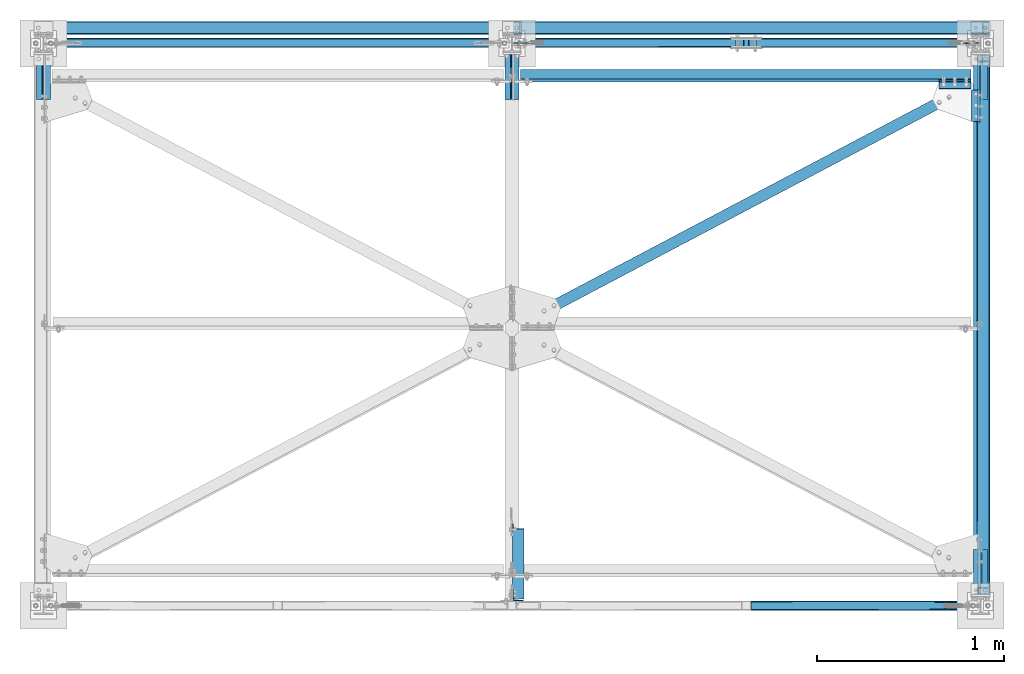
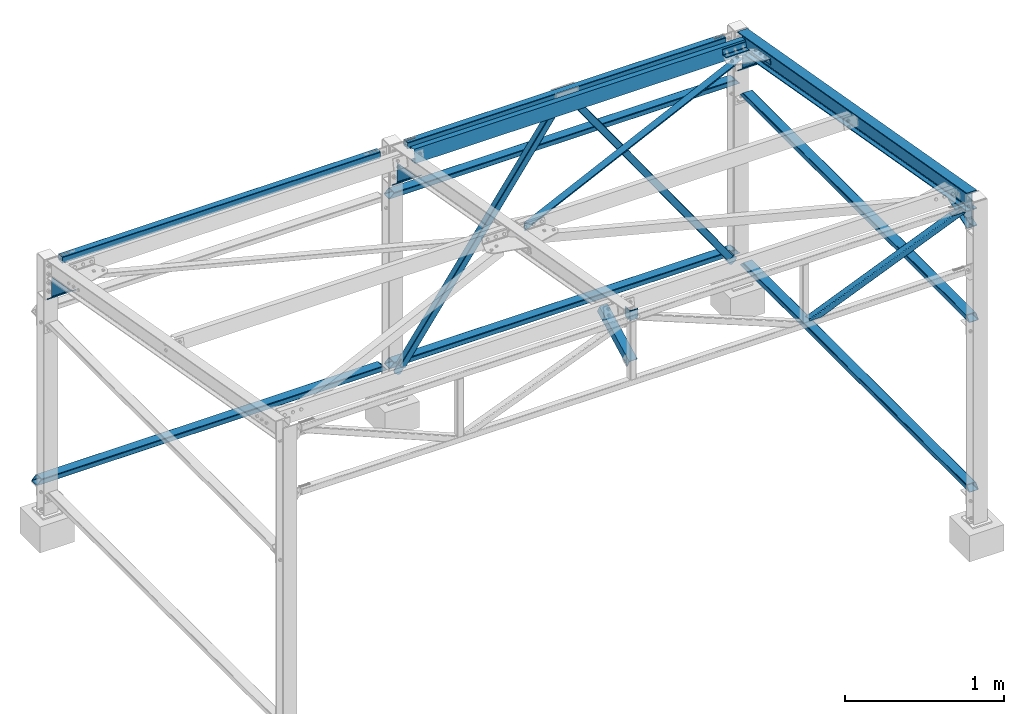
# One storey, part 6 of 28: 14 beams, 9 members, 19 elements without a shape of their own.
"""IFC2X3 building model written with IfcOpenShell, lengths in millimetres."""

from ifc_helpers import new_model, si_unit, frame, origin_with_axes, origin_2d_with_axis, place, context, subcontext, project, spatial, rectangle, hollow_rectangle, i_section, l_section, c_section, extrude, boolean, clip, halfspace, material, type_object, element, aggregate, save


model = new_model("IFC2X3")

# Units and contexts
model_context = context("Model", 3, precision=1e-05, world=origin_with_axes())
body_context = subcontext(model_context, "Body", "Model", "MODEL_VIEW")
ifc_project = project(units=[si_unit("LENGTHUNIT", "METRE", prefix="MILLI"), si_unit("AREAUNIT", "SQUARE_METRE"), si_unit("VOLUMEUNIT", "CUBIC_METRE"), si_unit("MASSUNIT", "GRAM", prefix="KILO"), si_unit("TIMEUNIT", "SECOND"), si_unit("PLANEANGLEUNIT", "RADIAN"), si_unit("SOLIDANGLEUNIT", "STERADIAN"), si_unit("THERMODYNAMICTEMPERATUREUNIT", "DEGREE_CELSIUS"), si_unit("LUMINOUSINTENSITYUNIT", "LUMEN")], contexts=[model_context])

# Site, building, storey
site_placement = place(None, origin_with_axes())
site = spatial("IfcSite", under=ifc_project, at=site_placement, CompositionType="ELEMENT")
building_placement = place(site_placement, origin_with_axes())
building = spatial("IfcBuilding", under=site, at=building_placement, Name="Undefined", CompositionType="ELEMENT")
storey_placement = place(building_placement, origin_with_axes())
storey = spatial("IfcBuildingStorey", under=building, at=storey_placement, Name="Undefined", CompositionType="ELEMENT", Elevation=0.0)

# Assembly, member
assembly_1_placement = place(storey_placement, origin_with_axes())
assembly_1 = element("IfcElementAssembly", 1, at=assembly_1_placement, inside=storey, AssemblyPlace="NOTDEFINED", PredefinedType="NOTDEFINED")
ifc_material = material(Name="STEEL/S235JR")
member_type_1 = type_object("IfcMemberType", PredefinedType="NOTDEFINED")
member_1_placement = place(assembly_1_placement, frame((2584.59141781724, 3000.0, 452.793341408176), z_axis=(-0.816342906816188, 0.0, 0.577567535869959), x_axis=(-0.577567535869955, 0.0, -0.816342906816191)))
member_1 = element("IfcMember", 2, at=member_1_placement, type_object=member_type_1, material=ifc_material, context=body_context, shape_type="Clipping", body=[
    clip(clip(extrude(rectangle(XDim=6.0, YDim=60.0, at=origin_2d_with_axis()), frame((101.822640541409, -4.54747350886464e-13, 5.65229199786016e-15), z_axis=(-1.0, 0.0, 0.0), x_axis=(0.0, -1.0, 0.0)), (0.0, 0.0, 1.0), 101.82), halfspace(frame((146.82264054141, 2.99999999999955, -30.0000000000002), z_axis=(0.707106781249556, 0.0, 0.707106781123539), x_axis=(0.0, -1.0, 0.0)), False)), halfspace(frame((91.8226405414016, 2.99999999999955, -30.0000000000002), z_axis=(0.707106781123535, 0.0, -0.70710678124956), x_axis=(0.0, -1.0, 0.0)), False)),
])

assembly_2_placement = place(storey_placement, origin_with_axes())
assembly_2 = element("IfcElementAssembly", 3, at=assembly_2_placement, inside=storey, AssemblyPlace="NOTDEFINED", PredefinedType="NOTDEFINED")
member_2_placement = place(assembly_2_placement, frame((4915.40858218276, 3000.0, 452.793341408176), z_axis=(0.816342906816193, 0.0, 0.577567535869952), x_axis=(0.577567535869956, 0.0, -0.81634290681619)))
member_2 = element("IfcMember", 4, at=member_2_placement, type_object=member_type_1, material=ifc_material, context=body_context, shape_type="Clipping", body=[
    clip(clip(extrude(rectangle(XDim=6.0, YDim=60.0, at=origin_2d_with_axis()), frame((101.822640541409, -4.54747350886464e-13, 5.65229199786016e-15), z_axis=(-1.0, 0.0, 0.0), x_axis=(0.0, -1.0, 0.0)), (0.0, 0.0, 1.0), 101.82), halfspace(frame((146.82264054141, -3.00000000000045, -30.0000000000009), z_axis=(0.707106781249556, 0.0, 0.707106781123539), x_axis=(-0.707106781123536, 0.0, 0.707106781249559)), False)), halfspace(frame((91.8226405414016, -3.00000000000045, -30.0), z_axis=(0.707106781123535, 0.0, -0.70710678124956), x_axis=(0.707106781249556, 0.0, 0.707106781123539)), False)),
])

# Member
member_type_2 = type_object("IfcMemberType", PredefinedType="NOTDEFINED")
member_3_placement = place(assembly_1_placement, frame((2528.38079886693, 3003.11000000016, 373.344381385333), z_axis=(0.0, -1.0, 0.0), x_axis=(0.577567535869954, 0.0, 0.816342906816191)))
solid_1 = boolean("DIFFERENCE", extrude(rectangle(XDim=6.0, YDim=60.0, at=origin_2d_with_axis()), frame((-4.49961689598291, -9.17407910569932e-12, 3.11000000015792), z_axis=(1.0, 0.0, 0.0), x_axis=(0.0, 0.0, -1.0)), (0.0, 0.0, 1.0), 101.82), halfspace(frame((-49.4996168959854, -30.0000000000095, 6.11000000015792), z_axis=(-0.707106781249559, 0.707106781123536, 0.0), x_axis=(0.0, 0.0, -1.0)), False))
solid_2 = boolean("DIFFERENCE", extrude(rectangle(XDim=6.0, YDim=60.0, at=origin_2d_with_axis()), frame((-4.49961689598291, -9.17407910569932e-12, 3.11000000015792), z_axis=(1.0, 0.0, 0.0), x_axis=(0.0, 0.0, -1.0)), (0.0, 0.0, 1.0), 101.82), halfspace(frame((-49.4996168959854, -30.0000000000095, 6.11000000015792), z_axis=(-0.707106781249559, 0.707106781123536, 0.0), x_axis=(0.0, 0.0, -1.0)), False))
member_3 = element("IfcMember", 5, at=member_3_placement, type_object=member_type_2, material=ifc_material, context=body_context, shape_type="CSG", body=[
    boolean("DIFFERENCE", boolean("DIFFERENCE", boolean("DIFFERENCE", boolean("DIFFERENCE", extrude(hollow_rectangle(XDim=50.0, YDim=50.0, WallThickness=3.0, InnerFilletRadius=3.0, OuterFilletRadius=6.0, at=origin_2d_with_axis()), frame((2159.92057273327, 3.59699032681505e-13, 0.0), z_axis=(-1.0, 0.0, 0.0), x_axis=(0.0, -1.0, 0.0)), (0.0, 0.0, 1.0), 2159.92), solid_1), solid_2), halfspace(frame((2056.2476454801, 23.738158636309, -24.9999999997331), z_axis=(0.999768192719064, 0.0215304627738772, 0.0), x_axis=(0.0215304627738772, -0.999768192719064, 0.0)), False)), halfspace(frame((57.323023645426, -24.9999999999995, -25.0), z_axis=(-1.0, 0.0, 0.0), x_axis=(0.0, 1.0, 0.0)), False)),
])

aggregate(assembly_1, [member_1, member_3])

member_4_placement = place(assembly_2_placement, frame((4971.61920113307, 3003.11000000016, 373.344381385333), z_axis=(0.0, -1.0, 0.0), x_axis=(-0.577567535869954, 0.0, 0.816342906816191)))
solid_3 = boolean("DIFFERENCE", extrude(rectangle(XDim=6.0, YDim=60.0, at=origin_2d_with_axis()), frame((-4.49961689598291, -9.17407910569932e-12, 3.11000000015792), z_axis=(1.0, 0.0, 0.0), x_axis=(0.0, 0.0, 1.0)), (0.0, 0.0, 1.0), 101.82), halfspace(frame((-49.4996168959851, 30.00000000001, 6.11000000015792), z_axis=(-0.707106781186548, -0.707106781186548, 0.0), x_axis=(0.707106781123531, -0.707106781249564, 0.0)), False))
member_4 = element("IfcMember", 6, at=member_4_placement, type_object=member_type_2, material=ifc_material, context=body_context, shape_type="CSG", body=[
    boolean("DIFFERENCE", boolean("DIFFERENCE", boolean("DIFFERENCE", extrude(hollow_rectangle(XDim=50.0, YDim=50.0, WallThickness=3.0, InnerFilletRadius=3.0, OuterFilletRadius=6.0, at=origin_2d_with_axis()), frame((2159.92057273327, 3.59699032681505e-13, 0.0), z_axis=(-1.0, 0.0, 0.0), x_axis=(0.0, -1.0, 0.0)), (0.0, 0.0, 1.0), 2159.92), solid_3), halfspace(frame((57.323023645426, 24.9999999999991, -25.0), z_axis=(-1.0, 0.0, 0.0), x_axis=(0.0, 0.0, 1.0)), False)), halfspace(frame((2056.2476454801, -23.738158636309, -24.9999999997331), z_axis=(0.999768192719064, -0.0215304627738776, 0.0), x_axis=(0.0, 0.0, 1.0)), False)),
])

aggregate(assembly_2, [member_2, member_4])

# Assembly, beam
assembly_3_placement = place(storey_placement, origin_with_axes())
assembly_3 = element("IfcElementAssembly", 7, at=assembly_3_placement, inside=storey, Name="FA", AssemblyPlace="NOTDEFINED", PredefinedType="NOTDEFINED")
beam_type_1 = type_object("IfcBeamType", PredefinedType="NOTDEFINED")
beam_1_placement = place(assembly_3_placement, frame((2532.51, 55.0, 2660.99989966715), z_axis=(0.0, 1.0, 0.0), x_axis=(0.0, 0.0, -1.0)))
beam_1 = element("IfcBeam", 8, at=beam_1_placement, type_object=beam_type_1, material=ifc_material, Name="FA", context=body_context, shape_type="SweptSolid", body=[
    extrude(l_section(Depth=60.0, Width=60.0, Thickness=6.0, FilletRadius=9.0, at=origin_2d_with_axis()), frame((75.0, 0.0, 0.0), z_axis=(-1.0, 0.0, 0.0), x_axis=(0.0, -1.0, 0.0)), (0.0, 0.0, 1.0), 75.0),
])
aggregate(assembly_3, [beam_1])

assembly_4_placement = place(storey_placement, origin_with_axes())
assembly_4 = element("IfcElementAssembly", 9, at=assembly_4_placement, inside=storey, AssemblyPlace="NOTDEFINED", PredefinedType="NOTDEFINED")
beam_type_2 = type_object("IfcBeamType", PredefinedType="NOTDEFINED")
beam_2_placement = place(assembly_4_placement, frame((4947.65000011394, 2782.58003669103, 2163.62774213601), z_axis=(0.0, -0.984742283021841, 0.17401906800386), x_axis=(-1.0, 0.0, 0.0)))
beam_2 = element("IfcBeam", 10, at=beam_2_placement, type_object=beam_type_2, material=ifc_material, context=body_context, shape_type="SweptSolid", body=[
    extrude(l_section(Depth=45.0, Width=45.0, Thickness=4.0, FilletRadius=7.0, EdgeRadius=3.5, at=origin_2d_with_axis()), frame((169.999999999638, 0.0, 0.0), z_axis=(-1.0, 0.0, 0.0), x_axis=(0.0, -1.0, 0.0)), (0.0, 0.0, 1.0), 170.0),
])
aggregate(assembly_4, [beam_2])

assembly_5_placement = place(storey_placement, origin_with_axes())
assembly_5 = element("IfcElementAssembly", 11, at=assembly_5_placement, inside=storey, AssemblyPlace="NOTDEFINED", PredefinedType="NOTDEFINED")
beam_3_placement = place(assembly_5_placement, frame((4975.15000012328, 2746.45063233392, 2117.20666749448), z_axis=(-1.0, 0.0, 0.0), x_axis=(0.0, -0.984742283021841, 0.17401906800386)))
beam_3 = element("IfcBeam", 12, at=beam_3_placement, type_object=beam_type_2, material=ifc_material, context=body_context, shape_type="SweptSolid", body=[
    extrude(l_section(Depth=45.0, Width=45.0, Thickness=4.0, FilletRadius=7.0, EdgeRadius=3.5, at=origin_2d_with_axis()), frame((169.999999999638, 0.0, 0.0), z_axis=(-1.0, 0.0, 0.0), x_axis=(0.0, -1.0, 0.0)), (0.0, 0.0, 1.0), 170.0),
])
aggregate(assembly_5, [beam_3])

# Assembly, member
assembly_6_placement = place(storey_placement, origin_with_axes())
assembly_6 = element("IfcElementAssembly", 13, at=assembly_6_placement, inside=storey, AssemblyPlace="NOTDEFINED", PredefinedType="NOTDEFINED")
member_type_3 = type_object("IfcMemberType", Name="IPE140", PredefinedType="NOTDEFINED")
member_5_placement = place(assembly_6_placement, frame((2499.99999999997, 2984.1132847924, 1922.77267917178), z_axis=(0.0, 0.630189782914748, 0.776441135894964), x_axis=(0.0, -0.776441135894964, 0.630189782914748)))
member_5 = element("IfcMember", 14, at=member_5_placement, type_object=member_type_3, material=ifc_material, context=body_context, shape_type="Clipping", body=[
    clip(clip(clip(extrude(i_section(OverallWidth=73.0, OverallDepth=140.0, WebThickness=4.699999809, FlangeThickness=6.900000095, FilletRadius=7.0, at=origin_2d_with_axis()), frame((538.073020824243, 0.0, -8.96071584973028e-14), z_axis=(-1.0, 0.0, 0.0), x_axis=(0.0, -1.0, 0.0)), (0.0, 0.0, 1.0), 653.41), halfspace(frame((75.0040214740868, 36.5, 70.0), z_axis=(0.485458962736208, 0.0, 0.874259455481658), x_axis=(0.874259455481658, 0.0, -0.485458962736208)), False)), halfspace(frame((309.102633600927, 1.54614099301398e-11, -70.0000000728337), z_axis=(0.776441135894964, 0.0, -0.630189782914748), x_axis=(0.0, -1.0, 0.0)), False)), halfspace(frame((821.412970664735, 1.54614099301398e-11, 942.042462898728), z_axis=(-0.776441135894964, 0.0, 0.630189782914748), x_axis=(0.0, -1.0, 0.0)), False)),
])
aggregate(assembly_6, [member_5])

assembly_7_placement = place(storey_placement, origin_with_axes())
assembly_7 = element("IfcElementAssembly", 15, at=assembly_7_placement, inside=storey, AssemblyPlace="NOTDEFINED", PredefinedType="NOTDEFINED")
member_6_placement = place(assembly_7_placement, frame((5000.00000000163, 2984.11328479234, 1922.77267917227), z_axis=(0.0, 0.630189782914748, 0.776441135894964), x_axis=(0.0, -0.776441135894964, 0.630189782914748)))
member_6 = element("IfcMember", 16, at=member_6_placement, type_object=member_type_3, material=ifc_material, context=body_context, shape_type="Clipping", body=[
    clip(clip(clip(extrude(i_section(OverallWidth=73.0, OverallDepth=140.0, WebThickness=4.699999809, FlangeThickness=6.900000095, FilletRadius=7.0, at=origin_2d_with_axis()), frame((538.073020824243, 0.0, -8.96071584973028e-14), z_axis=(-1.0, 0.0, 0.0), x_axis=(0.0, -1.0, 0.0)), (0.0, 0.0, 1.0), 653.41), halfspace(frame((75.0040214740868, 36.5, 70.0), z_axis=(0.485458962736208, 0.0, 0.874259455481658), x_axis=(0.874259455481658, 0.0, -0.485458962736208)), False)), halfspace(frame((309.102633600927, 1.54614099301398e-11, -70.0000000728337), z_axis=(0.776441135894964, 0.0, -0.630189782914748), x_axis=(0.0, -1.0, 0.0)), False)), halfspace(frame((821.412970664735, 1.54614099301398e-11, 942.042462898728), z_axis=(-0.776441135894964, 0.0, 0.630189782914748), x_axis=(0.0, -1.0, 0.0)), False)),
])

assembly_8_placement = place(storey_placement, origin_with_axes())
assembly_8 = element("IfcElementAssembly", 17, at=assembly_8_placement, inside=storey, AssemblyPlace="NOTDEFINED", PredefinedType="NOTDEFINED")
member_7_placement = place(assembly_8_placement, frame((-4.16338693337359e-10, 2984.11328479246, 1922.77267917177), z_axis=(0.0, 0.630189782914748, 0.776441135894964), x_axis=(0.0, -0.776441135894964, 0.630189782914748)))
member_7 = element("IfcMember", 18, at=member_7_placement, type_object=member_type_3, material=ifc_material, context=body_context, shape_type="Clipping", body=[
    clip(clip(clip(extrude(i_section(OverallWidth=73.0, OverallDepth=140.0, WebThickness=4.699999809, FlangeThickness=6.900000095, FilletRadius=7.0, at=origin_2d_with_axis()), frame((538.073020824243, 0.0, -8.96071584973028e-14), z_axis=(-1.0, 0.0, 0.0), x_axis=(0.0, -1.0, 0.0)), (0.0, 0.0, 1.0), 653.41), halfspace(frame((75.0040214740868, 36.5, 70.0), z_axis=(0.485458962736208, 0.0, 0.874259455481658), x_axis=(0.874259455481658, 0.0, -0.485458962736208)), False)), halfspace(frame((309.102633600927, 1.54614099301398e-11, -70.0000000728337), z_axis=(0.776441135894964, 0.0, -0.630189782914748), x_axis=(0.0, -1.0, 0.0)), False)), halfspace(frame((821.412970664735, 1.54614099301398e-11, 942.042462898728), z_axis=(-0.776441135894964, 0.0, 0.630189782914748), x_axis=(0.0, -1.0, 0.0)), False)),
])
aggregate(assembly_8, [member_7])

# Assembly, beam
assembly_9_placement = place(storey_placement, origin_with_axes())
assembly_9 = element("IfcElementAssembly", 19, at=assembly_9_placement, inside=storey, AssemblyPlace="NOTDEFINED", PredefinedType="NOTDEFINED")
beam_type_3 = type_object("IfcBeamType", PredefinedType="NOTDEFINED")
beam_4_placement = place(assembly_9_placement, frame((5015.00000000054, 3000.00000000009, 1699.9998958987), z_axis=(1.0, 0.0, 0.0), x_axis=(0.0, -1.0, 0.0)))
beam_4 = element("IfcBeam", 20, at=beam_4_placement, type_object=beam_type_3, material=ifc_material, context=body_context, shape_type="Clipping", body=[
    clip(clip(clip(clip(clip(clip(extrude(hollow_rectangle(XDim=40.0, YDim=70.0, WallThickness=3.0, InnerFilletRadius=3.0, OuterFilletRadius=6.0, at=origin_2d_with_axis()), frame((3000.0, 0.0, 0.0), z_axis=(-1.0, 0.0, 0.0), x_axis=(0.0, -1.0, 0.0)), (0.0, 0.0, 1.0), 3000.0), halfspace(frame((63.0031151709718, -20.0000000001187, -35.0000000000191), z_axis=(-1.0, 0.0, 0.0), x_axis=(0.0, 1.0, 0.0)), False)), halfspace(frame((98.0031151678127, -20.0000000001191, -35.00000000002), z_axis=(-0.707079247150489, -0.7071343141505, 0.0), x_axis=(-0.7071343141505, 0.707079247150489, 0.0)), False)), halfspace(frame((2936.99688482905, -20.0000000001187, -35.0000000000191), z_axis=(1.0, 0.0, 0.0), x_axis=(0.0, 0.0, 1.0)), False)), halfspace(frame((2901.99688483221, -20.0000000001191, -35.0000000000191), z_axis=(0.707079247150487, -0.707134314150502, 0.0), x_axis=(0.0, 0.0, 1.0)), False)), halfspace(frame((47.9999999999882, 20.0000000000045, -40.0000000000064), z_axis=(-1.0, 0.0, 0.0), x_axis=(0.0, 0.0, 1.0)), False)), halfspace(frame((2942.00000000001, -20.0000000000045, -40.0000000000064), z_axis=(1.0, 0.0, 0.0), x_axis=(0.0, 0.0, 1.0)), False)),
])
aggregate(assembly_9, [beam_4])

assembly_10_placement = place(storey_placement, origin_with_axes())
assembly_10 = element("IfcElementAssembly", 21, at=assembly_10_placement, inside=storey, AssemblyPlace="NOTDEFINED", PredefinedType="NOTDEFINED")
beam_5_placement = place(assembly_10_placement, frame((5015.00000000052, 3000.0000000004, 399.999895898523), z_axis=(1.0, 0.0, 0.0), x_axis=(0.0, -1.0, 0.0)))
beam_5 = element("IfcBeam", 22, at=beam_5_placement, type_object=beam_type_3, material=ifc_material, context=body_context, shape_type="Clipping", body=[
    clip(clip(clip(clip(clip(clip(extrude(hollow_rectangle(XDim=40.0, YDim=70.0, WallThickness=3.0, InnerFilletRadius=3.0, OuterFilletRadius=6.0, at=origin_2d_with_axis()), frame((3000.00109932641, 0.0, 0.0), z_axis=(-1.0, 0.0, 0.0), x_axis=(0.0, -1.0, 0.0)), (0.0, 0.0, 1.0), 3000.0), halfspace(frame((63.0031151709718, -20.0000000001187, -35.0000000000191), z_axis=(-1.0, 0.0, 0.0), x_axis=(0.0, 1.0, 0.0)), False)), halfspace(frame((98.0031151678127, -20.0000000001191, -35.00000000002), z_axis=(-0.707079247150489, -0.7071343141505, 0.0), x_axis=(-0.7071343141505, 0.707079247150489, 0.0)), False)), halfspace(frame((2936.99688482905, -20.0000000001187, -35.0000000000191), z_axis=(1.0, 0.0, 0.0), x_axis=(0.0, 0.0, 1.0)), False)), halfspace(frame((2901.99688483221, -20.0000000001191, -35.0000000000191), z_axis=(0.707079247150487, -0.707134314150502, 0.0), x_axis=(0.0, 0.0, 1.0)), False)), halfspace(frame((47.9999999999882, 20.0000000000045, -40.0000000000064), z_axis=(-1.0, 0.0, 0.0), x_axis=(0.0, 0.0, 1.0)), False)), halfspace(frame((2942.00000000001, -20.0000000000045, -40.0000000000064), z_axis=(1.0, 0.0, 0.0), x_axis=(0.0, 0.0, 1.0)), False)),
])
aggregate(assembly_10, [beam_5])

assembly_11_placement = place(storey_placement, origin_with_axes())
assembly_11 = element("IfcElementAssembly", 23, at=assembly_11_placement, inside=storey, AssemblyPlace="NOTDEFINED", PredefinedType="NOTDEFINED")
beam_6_placement = place(assembly_11_placement, frame((2499.99999999999, 3083.00000000085, 399.999895901682), z_axis=(0.0, -1.0, 0.0), x_axis=(-1.0, 0.0, 0.0)))
beam_6 = element("IfcBeam", 24, at=beam_6_placement, type_object=beam_type_3, material=ifc_material, context=body_context, shape_type="Clipping", body=[
    clip(clip(clip(clip(extrude(hollow_rectangle(XDim=40.0, YDim=70.0, WallThickness=3.0, InnerFilletRadius=3.0, OuterFilletRadius=6.0, at=origin_2d_with_axis()), frame((2550.00000000037, 0.0, 0.0), z_axis=(-1.0, 0.0, 0.0), x_axis=(0.0, -1.0, 0.0)), (0.0, 0.0, 1.0), 2550.0), halfspace(frame((2545.00000000037, -20.0000000000045, -35.0000000000159), z_axis=(1.0, 0.0, 0.0), x_axis=(0.0, 0.0, 1.0)), False)), halfspace(frame((7.5, 20.0000000000045, -35.0000000000118), z_axis=(-1.0, 0.0, 0.0), x_axis=(0.0, 0.0, 1.0)), False)), halfspace(frame((2.50000000003047, 20.0000000004552, -35.0000000000719), z_axis=(-0.707106781186548, -0.707106781186548, 0.0), x_axis=(0.0, 0.0, 1.0)), False)), halfspace(frame((2521.71572875313, -8.28427124701284, -35.0000000001091), z_axis=(0.707106781123531, -0.707106781249564, 0.0), x_axis=(0.0, 0.0, 1.0)), False)),
])
aggregate(assembly_11, [beam_6])

assembly_12_placement = place(storey_placement, origin_with_axes())
assembly_12 = element("IfcElementAssembly", 25, at=assembly_12_placement, inside=storey, AssemblyPlace="NOTDEFINED", PredefinedType="NOTDEFINED")
beam_7_placement = place(assembly_12_placement, frame((5050.00000000036, 3083.00000000009, 1699.99989590197), z_axis=(0.0, -1.0, 0.0), x_axis=(-1.0, 0.0, 0.0)))
beam_7 = element("IfcBeam", 26, at=beam_7_placement, type_object=beam_type_3, material=ifc_material, context=body_context, shape_type="Clipping", body=[
    clip(clip(clip(clip(extrude(hollow_rectangle(XDim=40.0, YDim=70.0, WallThickness=3.0, InnerFilletRadius=3.0, OuterFilletRadius=6.0, at=origin_2d_with_axis()), frame((2550.00000000037, 0.0, 0.0), z_axis=(-1.0, 0.0, 0.0), x_axis=(0.0, -1.0, 0.0)), (0.0, 0.0, 1.0), 2550.0), halfspace(frame((2542.50000000037, -20.0000000000045, -35.0000000000155), z_axis=(1.0, 0.0, 0.0), x_axis=(0.0, 0.0, 1.0)), False)), halfspace(frame((4.99980429827701, 20.0000000000041, -35.0000000000114), z_axis=(-1.0, 0.0, 0.0), x_axis=(0.0, 0.0, 1.0)), False)), halfspace(frame((-2.99999999999818, 23.000000000005, -35.0000000000132), z_axis=(-0.707106781186548, -0.707106781186548, 0.0), x_axis=(0.0, 0.0, 1.0)), False)), halfspace(frame((2519.21572875294, -8.28427124701284, -35.0000000000814), z_axis=(0.707106781123531, -0.707106781249564, 0.0), x_axis=(0.0, 0.0, 1.0)), False)),
])
aggregate(assembly_12, [beam_7])

assembly_13_placement = place(storey_placement, origin_with_axes())
assembly_13 = element("IfcElementAssembly", 27, at=assembly_13_placement, inside=storey, AssemblyPlace="NOTDEFINED", PredefinedType="NOTDEFINED")
beam_8_placement = place(assembly_13_placement, frame((5050.00000000036, 3083.00000000082, 399.999895901682), z_axis=(0.0, -1.0, 0.0), x_axis=(-1.0, 0.0, 0.0)))
beam_8 = element("IfcBeam", 28, at=beam_8_placement, type_object=beam_type_3, material=ifc_material, context=body_context, shape_type="Clipping", body=[
    clip(clip(clip(clip(extrude(hollow_rectangle(XDim=40.0, YDim=70.0, WallThickness=3.0, InnerFilletRadius=3.0, OuterFilletRadius=6.0, at=origin_2d_with_axis()), frame((2550.00000000037, 0.0, 0.0), z_axis=(-1.0, 0.0, 0.0), x_axis=(0.0, -1.0, 0.0)), (0.0, 0.0, 1.0), 2550.0), halfspace(frame((2542.50000000037, -20.0000000000045, -35.0000000000155), z_axis=(1.0, 0.0, 0.0), x_axis=(0.0, 0.0, 1.0)), False)), halfspace(frame((4.99980429827701, 20.0000000000041, -35.0000000000114), z_axis=(-1.0, 0.0, 0.0), x_axis=(0.0, 0.0, 1.0)), False)), halfspace(frame((3.63797880709171e-12, 20.0000000000043, -35.0000000000109), z_axis=(-0.707106781186548, -0.707106781186548, 0.0), x_axis=(0.0, 0.0, 1.0)), False)), halfspace(frame((2519.21572875294, -8.28427124701284, -35.0000000000814), z_axis=(0.707106781123531, -0.707106781249564, 0.0), x_axis=(0.0, 0.0, 1.0)), False)),
])
aggregate(assembly_13, [beam_8])

# Beam
beam_type_4 = type_object("IfcBeamType", Name="IPE140", PredefinedType="NOTDEFINED")
beam_9_placement = place(assembly_7_placement, frame((5000.00000000166, 37.7267546246773, 2474.75029870687), z_axis=(0.0, -0.318189219847037, 0.948027225544253), x_axis=(0.0, 0.948027225544253, 0.318189219847037)))
beam_9 = element("IfcBeam", 29, at=beam_9_placement, type_object=beam_type_4, material=ifc_material, context=body_context, shape_type="Clipping", body=[
    clip(clip(clip(extrude(i_section(OverallWidth=73.0, OverallDepth=140.0, WebThickness=4.699999809, FlangeThickness=6.900000095, FilletRadius=7.0, at=origin_2d_with_axis()), frame((431.022965559247, 0.0, 0.0), z_axis=(-1.0, 0.0, 0.0), x_axis=(0.0, -1.0, 0.0)), (0.0, 0.0, 1.0), 561.9), halfspace(frame((11.0971479142066, 36.5, 70.0000000000005), z_axis=(0.478309193016606, 0.0, 0.878191502962653), x_axis=(0.878191502962653, 0.0, -0.478309193016606)), False)), halfspace(frame((253.157286526225, 5.45696821063757e-12, -70.0000000485638), z_axis=(0.948027225544253, 0.0, -0.318189219847037), x_axis=(0.0, -1.0, 0.0)), False)), halfspace(frame((404.867478983601, 4.54747350886464e-12, 1136.28031650857), z_axis=(-0.948027225544253, 0.0, 0.318189219847037), x_axis=(0.0, -1.0, 0.0)), False)),
])

beam_10_placement = place(assembly_7_placement, frame((5000.00000000165, 2999.99999999986, 2090.17175182066), z_axis=(0.0, 0.17401906800386, 0.984742283021841), x_axis=(0.0, -0.984742283021841, 0.17401906800386)))
beam_10 = element("IfcBeam", 30, at=beam_10_placement, type_object=beam_type_4, material=ifc_material, context=body_context, shape_type="Clipping", body=[
    clip(clip(extrude(i_section(OverallWidth=73.0, OverallDepth=140.0, WebThickness=4.699999809, FlangeThickness=6.900000095, FilletRadius=7.0, at=origin_2d_with_axis()), frame((3010.54026756728, 0.0, 4.54747350886464e-13), z_axis=(-1.0, 0.0, 0.0), x_axis=(0.0, -1.0, 0.0)), (0.0, 0.0, 1.0), 3010.54), halfspace(frame((2973.18264455337, 0.0, -69.9999999999995), z_axis=(-0.984742283021841, 0.0, 0.17401906800386), x_axis=(0.0, 1.0, 0.0)), True)), halfspace(frame((48.5595734669414, 0.0, -69.9999999999995), z_axis=(0.984742283021842, 0.0, -0.174019068003857), x_axis=(0.0, -1.0, 0.0)), True)),
])

aggregate(assembly_7, [member_6, beam_9, beam_10])

# Assembly, beam
assembly_14_placement = place(storey_placement, origin_with_axes())
assembly_14 = element("IfcElementAssembly", 31, at=assembly_14_placement, inside=storey, AssemblyPlace="NOTDEFINED", PredefinedType="NOTDEFINED")
beam_type_5 = type_object("IfcBeamType", PredefinedType="NOTDEFINED")
beam_11_placement = place(assembly_14_placement, frame((5006.61383909633, 2799.56969704349, 2101.21900206193), z_axis=(9.84741745924111e-10, -0.174019067034142, -0.984742283193205), x_axis=(-0.88137512674611, -0.46520906186599, 0.0822095779763182)))
beam_11 = element("IfcBeam", 32, at=beam_11_placement, type_object=beam_type_5, material=ifc_material, context=body_context, shape_type="Clipping", body=[
    clip(clip(extrude(l_section(Depth=60.0, Width=60.0, Thickness=4.0, FilletRadius=8.0, EdgeRadius=4.0, at=origin_2d_with_axis()), frame((2836.47668766142, -1.38289351217352e-13, 4.15383329293286e-13), z_axis=(-1.0, 0.0, 0.0), x_axis=(0.0, -1.0, 0.0)), (0.0, 0.0, 1.0), 2836.48), halfspace(frame((2674.85994898802, -30.0000000482789, -29.999999691423), z_axis=(0.999999998517212, -5.44571059916747e-05, 5.95048702313855e-10), x_axis=(0.0, 0.0, 1.0)), False)), halfspace(frame((172.584792210221, -30.0000000739755, 1.48520484799519e-08), z_axis=(-1.0, 0.0, 0.0), x_axis=(0.0, 0.0, -1.0)), False)),
])
aggregate(assembly_14, [beam_11])

assembly_15_placement = place(storey_placement, origin_with_axes())
assembly_15 = element("IfcElementAssembly", 33, at=assembly_15_placement, inside=storey, Name="C_100", AssemblyPlace="NOTDEFINED", PredefinedType="NOTDEFINED")
beam_type_6 = type_object("IfcBeamType", Name="CC100-2-15-50", PredefinedType="NOTDEFINED")
beam_12_placement = place(assembly_15_placement, frame((5000.00000000559, 2826.83201863084, 2141.08307307931), z_axis=(0.0, 0.17401906800386, 0.984742283021841), x_axis=(-1.0, 0.0, 0.0)))
beam_12 = element("IfcBeam", 34, at=beam_12_placement, type_object=beam_type_6, material=ifc_material, Name="C_100", context=body_context, shape_type="Clipping", body=[
    clip(clip(extrude(c_section(Depth=100.0, Width=50.0, WallThickness=2.0, Girth=15.0, at=origin_2d_with_axis()), frame((2499.99999998992, 0.0, 0.0), z_axis=(-1.0, 0.0, 0.0), x_axis=(0.0, -1.0, 0.0)), (0.0, 0.0, 1.0), 2500.0), halfspace(frame((52.3499998914995, 25.000000020435, -49.9999999971592), z_axis=(-1.0, 0.0, 0.0), x_axis=(0.0, 0.0, 1.0)), False)), halfspace(frame((2453.50228739671, -24.9999999994811, -50.0000000004602), z_axis=(1.0, 0.0, 0.0), x_axis=(0.0, 0.0, 1.0)), False)),
])
aggregate(assembly_15, [beam_12])

# Assembly, member
assembly_16_placement = place(storey_placement, origin_with_axes())
assembly_16 = element("IfcElementAssembly", 35, at=assembly_16_placement, inside=storey, Name="TREILLIS", AssemblyPlace="NOTDEFINED", PredefinedType="NOTDEFINED")
member_type_4 = type_object("IfcMemberType", PredefinedType="NOTDEFINED")
member_8_placement = place(assembly_16_placement, frame((3749.80115017103, -0.000311427450764512, 2145.13439692566), z_axis=(-0.383484354011888, 0.0, 0.923547373028631), x_axis=(0.923547373028631, 0.0, 0.383484354011888)))
member_8 = element("IfcMember", 36, at=member_8_placement, type_object=member_type_4, material=ifc_material, Name="TREILLIS", context=body_context, shape_type="CSG", body=[
    boolean("DIFFERENCE", boolean("DIFFERENCE", boolean("DIFFERENCE", boolean("DIFFERENCE", boolean("DIFFERENCE", boolean("DIFFERENCE", extrude(hollow_rectangle(XDim=50.0, YDim=50.0, WallThickness=3.2, InnerFilletRadius=6.4, OuterFilletRadius=9.6, at=origin_2d_with_axis()), frame((1279.6957090624, 5.42101086242752e-20, 0.0), z_axis=(-1.0, 0.0, 0.0), x_axis=(0.0, -1.0, 0.0)), (0.0, 0.0, 1.0), 1279.7), extrude(rectangle(XDim=6.0, YDim=100.0, at=origin_2d_with_axis()), frame((1156.5325026316, 0.000311426983753194, 29.6177368659764), z_axis=(0.92354737302863, 0.0, -0.38348435401189), x_axis=(0.0, 1.0, 0.0)), (0.0, 0.0, 1.0), 149.94)), halfspace(frame((1237.74023332505, -25.0, -25.0), z_axis=(0.92354737302863, 0.0, -0.38348435401189), x_axis=(0.383484354011898, 0.0, 0.923547373028627)), False)), halfspace(frame((17.3266123635185, 25.0, -25.856797854952), z_axis=(-0.929888622470144, 0.0, 0.367841201880074), x_axis=(0.367841201880074, 0.0, 0.929888622470144)), False)), halfspace(frame((1243.42855263744, -24.9999956499896, -87.9252110921607), z_axis=(0.998859427014801, 0.0, -0.0477477231254339), x_axis=(0.0477477231254339, 0.0, 0.998859427014801)), False)), halfspace(frame((1212.57381465058, 25.0000043500104, 0.933808880962488), z_axis=(0.383484354011898, 0.0, 0.923547373028627), x_axis=(0.92354737302863, 0.0, -0.38348435401189)), False)), halfspace(frame((131.68735757431, 24.9989457266288, -27.669889204614), z_axis=(-0.38348435401189, 0.0, -0.92354737302863), x_axis=(-0.923547373028631, 0.0, 0.383484354011888)), False)),
])
aggregate(assembly_16, [member_8])

assembly_17_placement = place(storey_placement, origin_with_axes())
assembly_17 = element("IfcElementAssembly", 37, at=assembly_17_placement, inside=storey, AssemblyPlace="NOTDEFINED", PredefinedType="NOTDEFINED")
member_type_5 = type_object("IfcMemberType", PredefinedType="NOTDEFINED")
member_9_placement = place(assembly_17_placement, frame((2533.50335766618, 423.799929477261, 2436.45628682744), z_axis=(0.0, 0.459948397016301, -0.887945647031469), x_axis=(-6.16400000222243e-06, -0.887945647014599, -0.459948397007568)))
member_9 = element("IfcMember", 38, at=member_9_placement, type_object=member_type_5, material=ifc_material, context=body_context, shape_type="Clipping", body=[
    clip(clip(extrude(l_section(Depth=60.0, Width=60.0, Thickness=4.0, FilletRadius=8.0, EdgeRadius=4.0, at=origin_2d_with_axis()), frame((470.029603743321, -3.98130560555476e-19, 0.0), z_axis=(-1.0, 0.0, 0.0), x_axis=(0.0, -1.0, 0.0)), (0.0, 0.0, 1.0), 470.03), halfspace(frame((-17.0814841977988, 30.0034796970726, -29.9999996089211), z_axis=(-0.999999999974482, 7.14399999803088e-06, 1.34789456702057e-09), x_axis=(0.0, 0.0, 1.0)), False)), halfspace(frame((422.324198100071, -29.9996594186528, -30.0000002010993), z_axis=(0.999999999974482, -7.14400000182044e-06, -1.34789456702057e-09), x_axis=(0.0, 0.0, 1.0)), False)),
])
aggregate(assembly_17, [member_9])

# Assembly, beam
assembly_18_placement = place(storey_placement, origin_with_axes())
assembly_18 = element("IfcElementAssembly", 39, at=assembly_18_placement, inside=storey, AssemblyPlace="NOTDEFINED", PredefinedType="NOTDEFINED")
beam_type_7 = type_object("IfcBeamType", PredefinedType="NOTDEFINED")
beam_13_placement = place(assembly_18_placement, frame((2499.99999999999, 3002.99637465689, 2099.99989590206), z_axis=(0.0, -1.0, 0.0), x_axis=(-1.0, 0.0, 0.0)))
beam_13 = element("IfcBeam", 40, at=beam_13_placement, type_object=beam_type_7, material=ifc_material, context=body_context, shape_type="CSG", body=[
    boolean("DIFFERENCE", boolean("DIFFERENCE", boolean("DIFFERENCE", boolean("DIFFERENCE", boolean("DIFFERENCE", boolean("DIFFERENCE", extrude(hollow_rectangle(XDim=50.0, YDim=50.0, WallThickness=3.0, InnerFilletRadius=3.0, OuterFilletRadius=6.0, at=origin_2d_with_axis()), frame((2499.99999998992, 0.0, 0.0), z_axis=(-1.0, 0.0, 0.0), x_axis=(0.0, -1.0, 0.0)), (0.0, 0.0, 1.0), 2500.0), extrude(rectangle(XDim=7.0, YDim=60.0, at=origin_2d_with_axis()), frame((2332.50000000034, 4.21550794271752e-09, 1.51976564666256e-09), z_axis=(1.0, 0.0, 0.0), x_axis=(0.0, 0.0, 1.0)), (0.0, 0.0, 1.0), 124.0)), extrude(rectangle(XDim=7.0, YDim=60.0, at=origin_2d_with_axis()), frame((167.50000000002, -4.21687218477018e-09, 1.54568624566309e-09), z_axis=(-1.0, 0.0, 0.0), x_axis=(0.0, 0.0, -1.0)), (0.0, 0.0, 1.0), 124.0)), halfspace(frame((2402.50000000053, 24.9999999999823, -25.0000000000787), z_axis=(1.0, 0.0, 0.0), x_axis=(0.0, -1.0, 0.0)), False)), halfspace(frame((97.5000000000091, 25.0000000002588, 24.9999999999454), z_axis=(-1.0, 0.0, 0.0), x_axis=(0.0, -1.0, 0.0)), False)), halfspace(frame((2440.00000000036, -25.0000000000059, -25.0000000000123), z_axis=(1.0, 0.0, 0.0), x_axis=(0.0, 0.0, 1.0)), False)), halfspace(frame((60.0000000000082, 25.0000000000055, -25.000000000015), z_axis=(-1.0, 0.0, 0.0), x_axis=(0.0, 0.0, 1.0)), False)),
])
aggregate(assembly_18, [beam_13])

assembly_19_placement = place(storey_placement, origin_with_axes())
assembly_19 = element("IfcElementAssembly", 41, at=assembly_19_placement, inside=storey, AssemblyPlace="NOTDEFINED", PredefinedType="NOTDEFINED")
beam_14_placement = place(assembly_19_placement, frame((5000.00000000035, 3002.9963746569, 2099.99989590203), z_axis=(0.0, -1.0, 0.0), x_axis=(-1.0, 0.0, 0.0)))
beam_14 = element("IfcBeam", 42, at=beam_14_placement, type_object=beam_type_7, material=ifc_material, context=body_context, shape_type="CSG", body=[
    boolean("DIFFERENCE", boolean("DIFFERENCE", boolean("DIFFERENCE", boolean("DIFFERENCE", boolean("DIFFERENCE", boolean("DIFFERENCE", extrude(hollow_rectangle(XDim=50.0, YDim=50.0, WallThickness=3.0, InnerFilletRadius=3.0, OuterFilletRadius=6.0, at=origin_2d_with_axis()), frame((2499.99999998992, 0.0, 0.0), z_axis=(-1.0, 0.0, 0.0), x_axis=(0.0, -1.0, 0.0)), (0.0, 0.0, 1.0), 2500.0), extrude(rectangle(XDim=7.0, YDim=60.0, at=origin_2d_with_axis()), frame((2332.50000000034, 4.21550794271752e-09, 1.51976564666256e-09), z_axis=(1.0, 0.0, 0.0), x_axis=(0.0, 0.0, 1.0)), (0.0, 0.0, 1.0), 124.0)), extrude(rectangle(XDim=7.0, YDim=60.0, at=origin_2d_with_axis()), frame((167.50000000002, -4.21687218477018e-09, 1.54568624566309e-09), z_axis=(-1.0, 0.0, 0.0), x_axis=(0.0, 0.0, -1.0)), (0.0, 0.0, 1.0), 124.0)), halfspace(frame((97.5000000000091, 25.0000000002588, 24.9999999999454), z_axis=(-1.0, 0.0, 0.0), x_axis=(0.0, -1.0, 0.0)), False)), halfspace(frame((2402.50000000053, 24.9999999999823, -25.0000000000787), z_axis=(1.0, 0.0, 0.0), x_axis=(0.0, -1.0, 0.0)), False)), halfspace(frame((60.0000000000082, 25.0000000000055, -25.000000000015), z_axis=(-1.0, 0.0, 0.0), x_axis=(0.0, 0.0, 1.0)), False)), halfspace(frame((2440.00000000036, -20.0000000000045, -35.0000000000146), z_axis=(1.0, 0.0, 0.0), x_axis=(0.0, 0.0, 1.0)), False)),
])
aggregate(assembly_19, [beam_14])

save(model, "model.ifc")
